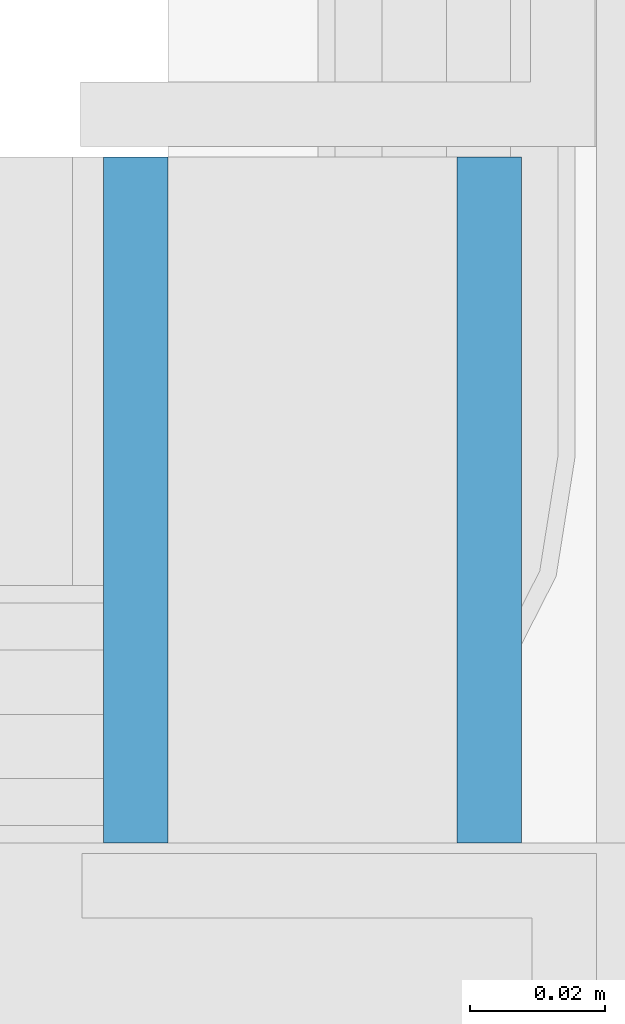
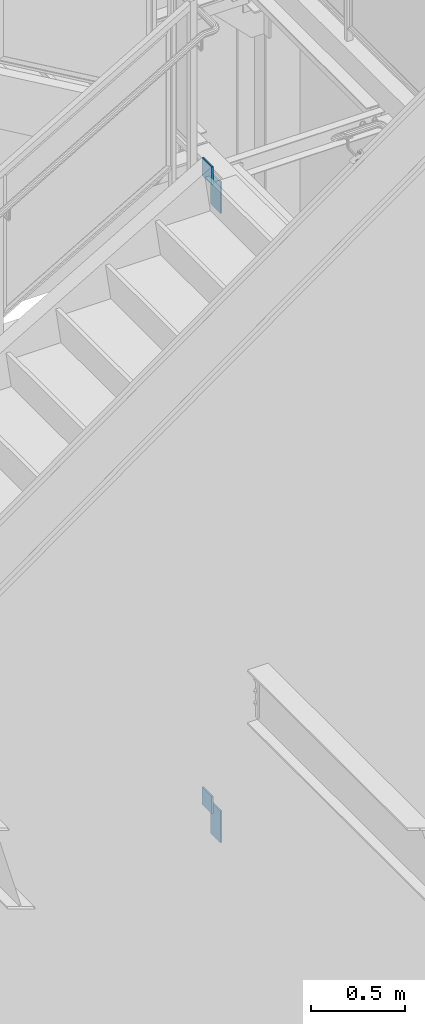
# One storey, part 574 of 1179: 4 columns, 2 elements without a shape of their own.
"""IFC2X3 building model written with IfcOpenShell, lengths in millimetres."""

from ifc_helpers import new_model, si_unit, frame, origin_with_axes, place, context, subcontext, project, spatial, faceted_brep, material, type_object, element, aggregate, save


model = new_model("IFC2X3")

# Units and contexts
model_context = context("Model", 3, precision=1e-05, world=origin_with_axes())
body_context = subcontext(model_context, "Body", "Model", "MODEL_VIEW")
ifc_project = project(units=[si_unit("LENGTHUNIT", "METRE", prefix="MILLI"), si_unit("AREAUNIT", "SQUARE_METRE"), si_unit("VOLUMEUNIT", "CUBIC_METRE"), si_unit("MASSUNIT", "GRAM", prefix="KILO"), si_unit("TIMEUNIT", "SECOND"), si_unit("PLANEANGLEUNIT", "RADIAN"), si_unit("SOLIDANGLEUNIT", "STERADIAN"), si_unit("THERMODYNAMICTEMPERATUREUNIT", "DEGREE_CELSIUS"), si_unit("LUMINOUSINTENSITYUNIT", "LUMEN")], contexts=[model_context])

# Site, building, storey
site_placement = place(None, origin_with_axes())
site = spatial("IfcSite", under=ifc_project, at=site_placement, CompositionType="ELEMENT")
building_placement = place(site_placement, origin_with_axes())
building = spatial("IfcBuilding", under=site, at=building_placement, Name="Undefined", CompositionType="ELEMENT")
storey_placement = place(building_placement, origin_with_axes())
storey = spatial("IfcBuildingStorey", under=building, at=storey_placement, Name="Undefined", CompositionType="ELEMENT", Elevation=0.0)

# Assembly, columns
assembly_1_placement = place(storey_placement, origin_with_axes())
assembly_1 = element("IfcElementAssembly", 1, at=assembly_1_placement, inside=storey, Name="STAIR", AssemblyPlace="NOTDEFINED", PredefinedType="RIGID_FRAME")
ifc_material = material(Name="STEEL/A36")
column_type = type_object("IfcColumnType", PredefinedType="NOTDEFINED")
column_1_placement = place(assembly_1_placement, frame((22899.6875001613, 39401.7499999899, 6128.3450009963), z_axis=(0.0, -1.0, 0.0), x_axis=(0.0, 0.0, 1.0)))
column_1 = element("IfcColumn", 2, at=column_1_placement, type_object=column_type, material=ifc_material, Name="PLATE", context=body_context, shape_type="Brep", body=[
    faceted_brep([(0.0, 4.76249999999982, -50.7999999999993), (0.0, 4.76249999999982, 50.7999999999993), (113.704998971606, 4.76250000000073, 50.8000000000029), (113.704998971606, 4.76250000000073, -50.8000000000029), (0.0, -4.76249999999982, 50.7999999999993), (113.704998971606, -4.76250000000073, 50.8000000000029), (0.0, -4.76249999999982, -50.7999999999993), (113.704998971606, -4.76250000000073, -50.8000000000029)], [[[0, 1, 2, 3]], [[1, 4, 5, 2]], [[4, 6, 7, 5]], [[6, 0, 3, 7]], [[5, 7, 3, 2]], [[6, 4, 1, 0]]]),
])
column_2_placement = place(assembly_1_placement, frame((22952.0750000079, 39401.7499999899, 5922.42405406844), z_axis=(0.0, -1.0, 0.0), x_axis=(0.0, 0.0, 1.0)))
column_2 = element("IfcColumn", 3, at=column_2_placement, type_object=column_type, material=ifc_material, Name="PLATE", context=body_context, shape_type="Brep", body=[
    faceted_brep([(0.0, 4.76249999999982, -50.7999999999993), (0.0, 4.76249999999982, 50.7999999999993), (205.920946955599, 4.76250000018263, 50.8000000000029), (205.920946955599, 4.76250000018263, -50.8000000000029), (0.0, -4.76249999999982, 50.7999999999993), (205.9209469556, -4.76249999981519, 50.8000000000029), (0.0, -4.76249999999982, -50.7999999999993), (205.9209469556, -4.76249999981519, -50.8000000000029)], [[[0, 1, 2, 3]], [[1, 4, 5, 2]], [[4, 6, 7, 5]], [[6, 0, 3, 7]], [[5, 7, 3, 2]], [[6, 4, 1, 0]]]),
])
aggregate(assembly_1, [column_1, column_2])

assembly_2_placement = place(storey_placement, origin_with_axes())
assembly_2 = element("IfcElementAssembly", 4, at=assembly_2_placement, inside=storey, Name="STAIR", AssemblyPlace="NOTDEFINED", PredefinedType="RIGID_FRAME")
column_3_placement = place(assembly_2_placement, frame((22899.6875004135, 39401.7499999987, 2054.82031200209), z_axis=(0.0, -1.0, 0.0), x_axis=(0.0, 0.0, 1.0)))
column_3 = element("IfcColumn", 5, at=column_3_placement, type_object=column_type, material=ifc_material, Name="PLATE", context=body_context, shape_type="Brep", body=[
    faceted_brep([(0.0, 4.76249999999982, -50.7999999999993), (0.0, 4.76249999999982, 50.7999999999993), (113.704998971606, 4.76250000000073, 50.8000000000029), (113.704998971606, 4.76250000000073, -50.8000000000029), (0.0, -4.76249999999982, 50.7999999999993), (113.704998971606, -4.76250000000073, 50.8000000000029), (0.0, -4.76249999999982, -50.7999999999993), (113.704998971606, -4.76250000000073, -50.8000000000029)], [[[0, 1, 2, 3]], [[1, 4, 5, 2]], [[4, 6, 7, 5]], [[6, 0, 3, 7]], [[5, 7, 3, 2]], [[6, 4, 1, 0]]]),
])
column_4_placement = place(assembly_2_placement, frame((22952.0750000082, 39401.7499999987, 1849.10186379797), z_axis=(0.0, -1.0, 0.0), x_axis=(0.0, 0.0, 1.0)))
column_4 = element("IfcColumn", 6, at=column_4_placement, type_object=column_type, material=ifc_material, Name="PLATE", context=body_context, shape_type="Brep", body=[
    faceted_brep([(0.0, 4.76249999999982, -50.7999999999993), (0.0, 4.76249999999982, 50.7999999999993), (205.718448201926, 4.76250000000073, 50.8000000000029), (205.718448201926, 4.76250000000073, -50.8000000000029), (0.0, -4.76249999999982, 50.7999999999993), (205.718448201926, -4.76250000000073, 50.8000000000029), (0.0, -4.76249999999982, -50.7999999999993), (205.718448201926, -4.76250000000073, -50.8000000000029)], [[[0, 1, 2, 3]], [[1, 4, 5, 2]], [[4, 6, 7, 5]], [[6, 0, 3, 7]], [[5, 7, 3, 2]], [[6, 4, 1, 0]]]),
])
aggregate(assembly_2, [column_3, column_4])

save(model, "model.ifc")
